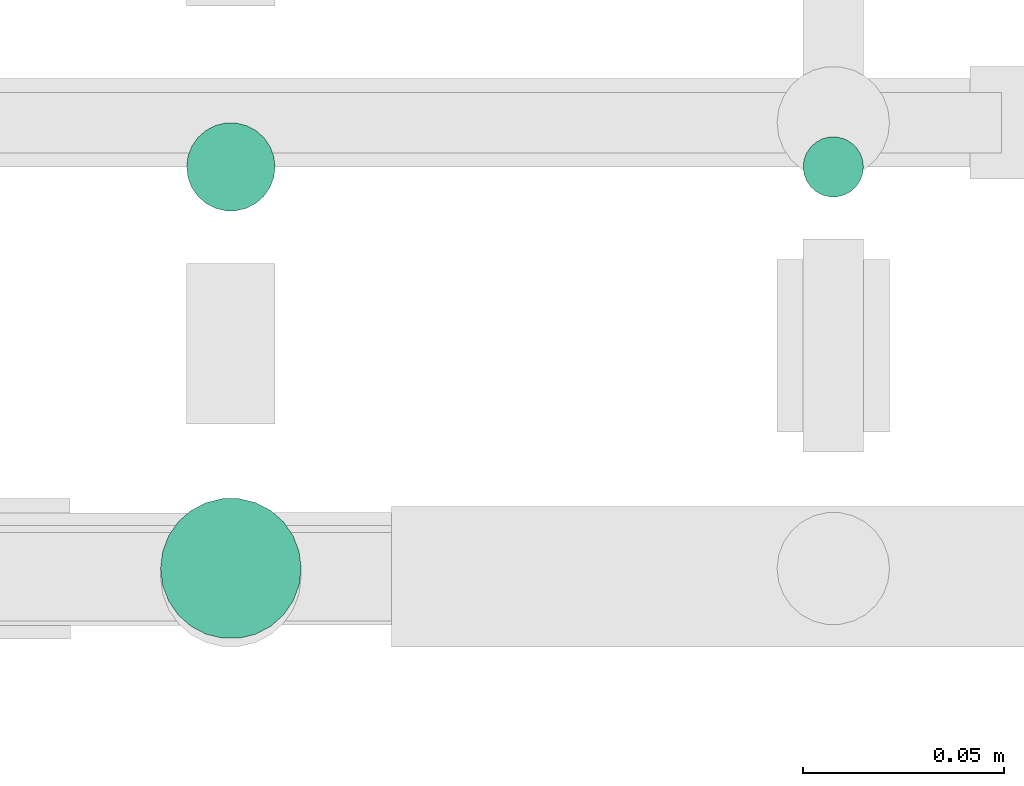
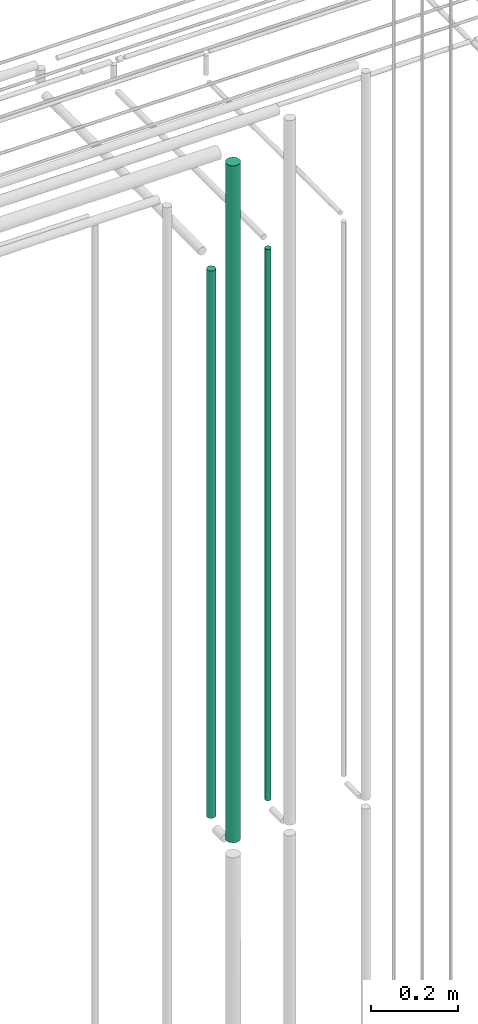
# One storey, part 93 of 331: 3 flow segments.
"""IFC2X3 building model written with IfcOpenShell, lengths in millimetres."""

import ifcopenshell
import ifcopenshell.guid

model = None  # the IFC model being written
_history = None  # IfcOwnerHistory: only IFC2X3 demands one
_inside = {}  # id of a spatial element -> (the spatial element, [elements in it])
_under = {}  # id of a project, library or spatial element -> (it, [spatial elements below it])
_declared = {}  # id of a project -> (the project, [libraries it declares])
_typed = {}  # id of a type object -> (the type object, [elements of that type])
_made_of = {}  # id of a material, layer set ... -> (it, [elements and type objects made of it])


def new_model(schema):
    """Start an empty IFC model of exactly this schema.

    Asked for "IFC4X3", IfcOpenShell would pick the latest addendum, in which some entities
    have other attributes; the version numbers below select the first issue.
    IFC2X3 requires an IfcOwnerHistory on every rooted entity: one is made here for all.
    """
    global model, _history
    if schema == "IFC4X3":
        model = ifcopenshell.file(schema_version=(4, 3, 0, 0))
    else:
        model = ifcopenshell.file(schema=schema)
    _inside.clear()
    _under.clear()
    _declared.clear()
    _typed.clear()
    _made_of.clear()
    _history = None
    if model.schema == "IFC2X3":
        org = make("IfcOrganization", Name="unknown")
        user = make(
            "IfcPersonAndOrganization",
            ThePerson=make("IfcPerson", FamilyName="unknown"),
            TheOrganization=org,
        )
        app = make(
            "IfcApplication",
            ApplicationDeveloper=org,
            Version="unknown",
            ApplicationFullName="unknown",
            ApplicationIdentifier="unknown",
        )
        _history = make(
            "IfcOwnerHistory",
            OwningUser=user,
            OwningApplication=app,
            ChangeAction="ADDED",
            CreationDate=0,
        )
    return model


def make(cls, **values):
    """One entity of the class cls with the attributes given. An attribute that is None is left unset."""
    return model.create_entity(
        cls, **{name: value for name, value in values.items() if value is not None}
    )


def entity(cls, *values):
    """Any entity or typed value of the class cls, its attributes in the order of the schema. None: left unset."""
    e = model.create_entity(cls)
    for i, value in enumerate(values):
        if value is not None:
            e[i] = value
    return e


def rooted(cls, **values):
    """An entity with a GlobalId (a new one), such as an element, a storey or a relation."""
    return make(cls, GlobalId=ifcopenshell.guid.new(), OwnerHistory=_history, **values)


def si_unit(unit_type, name, prefix=None):
    """IfcSIUnit, for example si_unit("LENGTHUNIT", "METRE", prefix="MILLI")."""
    return make("IfcSIUnit", UnitType=unit_type, Prefix=prefix, Name=name)


def converted_unit(unit_type, name, factor, base, dimensions=None, offset=None):
    """IfcConversionBasedUnit, such as the inch: factor (a typed value) times the base unit."""
    return make(
        "IfcConversionBasedUnit"
        if offset is None
        else "IfcConversionBasedUnitWithOffset",
        ConversionOffset=offset,
        Dimensions=None
        if dimensions is None
        else entity("IfcDimensionalExponents", *dimensions),
        UnitType=unit_type,
        Name=name,
        ConversionFactor=make(
            "IfcMeasureWithUnit", ValueComponent=factor, UnitComponent=base
        ),
    )


def derived_unit(unit_type, elements):
    """IfcDerivedUnit: a product of units, each with its exponent."""
    return make(
        "IfcDerivedUnit",
        Elements=[
            make("IfcDerivedUnitElement", Unit=unit, Exponent=power)
            for unit, power in elements
        ],
        UnitType=unit_type,
    )


def assignment(units):
    """IfcUnitAssignment: the units of a project."""
    return None if units is None else make("IfcUnitAssignment", Units=units)


def point(xyz):
    """IfcCartesianPoint."""
    return None if xyz is None else make("IfcCartesianPoint", Coordinates=xyz)


def direction(xyz):
    """IfcDirection."""
    return None if xyz is None else make("IfcDirection", DirectionRatios=xyz)


def frame(location, z_axis=None, x_axis=None):
    """IfcAxis2Placement3D, a coordinate frame: its origin and axes. An axis left out is left unset."""
    return make(
        "IfcAxis2Placement3D",
        Location=point(location),
        Axis=direction(z_axis),
        RefDirection=direction(x_axis),
    )


def frame_2d(location, x_axis=None):
    """IfcAxis2Placement2D, a coordinate frame in the plane: its origin and x axis."""
    return make(
        "IfcAxis2Placement2D", Location=point(location), RefDirection=direction(x_axis)
    )


def origin():
    """The frame at (0, 0, 0) with its axes left unset."""
    return frame((0.0, 0.0, 0.0))


def origin_2d_with_axis():
    """The frame at (0, 0) in the plane with the x axis (1, 0) written out."""
    return frame_2d((0.0, 0.0), x_axis=(1.0, 0.0))


def place(relative_to, where):
    """IfcLocalPlacement: puts the frame where relative to a parent placement (None: the world)."""
    return make(
        "IfcLocalPlacement", PlacementRelTo=relative_to, RelativePlacement=where
    )


def context(
    kind, dimensions, precision=None, world=None, true_north=None, identifier=None
):
    """IfcGeometricRepresentationContext, for example the 3D "Model" context."""
    return make(
        "IfcGeometricRepresentationContext",
        ContextIdentifier=identifier,
        ContextType=kind,
        CoordinateSpaceDimension=dimensions,
        Precision=precision,
        WorldCoordinateSystem=world,
        TrueNorth=true_north,
    )


def subcontext(parent, identifier, kind, view, scale=None):
    """IfcGeometricRepresentationSubContext, for example "Body" below "Model"."""
    return make(
        "IfcGeometricRepresentationSubContext",
        ContextIdentifier=identifier,
        ContextType=kind,
        ParentContext=parent,
        TargetScale=scale,
        TargetView=view,
    )


def project(units=None, contexts=None):
    """IfcProject with its units and contexts."""
    return rooted(
        "IfcProject",
        Name="project",
        RepresentationContexts=contexts,
        UnitsInContext=assignment(units),
    )


def spatial(cls, under=None, at=None, **own):
    """A site, building, storey or space (cls), placed at a placement, below another one or the project."""
    s = rooted(cls, ObjectPlacement=at, **own)
    if under is not None:
        _under.setdefault(under.id(), (under, []))[1].append(s)
    return s


def profile(cls, at=None, kind="AREA", **sizes):
    """A parametric profile (cls). Its sizes go by their IFC names, for example OverallWidth=200.0."""
    return make(cls, ProfileType=kind, Position=at, **sizes)


def circle(**sizes):
    """IfcCircleProfileDef."""
    return profile("IfcCircleProfileDef", **sizes)


def extrude(swept, where, along, depth):
    """IfcExtrudedAreaSolid: the profile swept, set in the frame where, extruded along a direction by depth."""
    return make(
        "IfcExtrudedAreaSolid",
        SweptArea=swept,
        Position=where,
        ExtrudedDirection=direction(along),
        Depth=depth,
    )


def shape(context_of_items, identifier, shape_type, items):
    """IfcShapeRepresentation: the items that make up one representation, for example the "Body"."""
    return make(
        "IfcShapeRepresentation",
        ContextOfItems=context_of_items,
        RepresentationIdentifier=identifier,
        RepresentationType=shape_type,
        Items=items,
    )


def made_of(thing, what):
    """Note that an element or type object is made of a material, layer set ...; save() writes the relation."""
    if what is not None:
        _made_of.setdefault(what.id(), (what, []))[1].append(thing)
    return thing


def type_object(cls, material=None, **own):
    """A type object (cls), such as IfcWallType, which elements share."""
    return made_of(rooted(cls, **own), material)


def element(
    cls,
    number,
    at=None,
    inside=None,
    cuts=None,
    type_object=None,
    material=None,
    context=None,
    identifier="Body",
    shape_type=None,
    held_by="IfcProductDefinitionShape",
    body=None,
    shapes=None,
    **own,
):
    """One element of the class cls, such as IfcWall. Its Tag is "e" and its number.

    at: its placement. inside: the storey or other place that contains it. cuts: it is an
    opening in that element (IfcRelVoidsElement). A single representation is given by context,
    identifier, shape_type and body (its items); several are given by shapes. held_by: the class
    of the entity that holds the representations. save() writes the other relations.
    """
    e = rooted(cls, Tag="e%d" % number, ObjectPlacement=at, **own)
    if body is not None:
        shapes = [shape(context, identifier, shape_type, body)]
    if shapes is not None:
        e.Representation = make(held_by, Representations=shapes)
    if inside is not None:
        _inside.setdefault(inside.id(), (inside, []))[1].append(e)
    if cuts is not None:
        rooted(
            "IfcRelVoidsElement", RelatingBuildingElement=cuts, RelatedOpeningElement=e
        )
    if type_object is not None:
        _typed.setdefault(type_object.id(), (type_object, []))[1].append(e)
    return made_of(e, material)


def aggregate(whole, parts):
    """IfcRelAggregates: a whole, such as a stair, and the parts it consists of."""
    return rooted("IfcRelAggregates", RelatingObject=whole, RelatedObjects=parts)


def save(model, path):
    """Write the relations noted so far, then the file.

    IfcRelAggregates (storeys below a building ...), IfcRelContainedInSpatialStructure (elements
    in a storey), IfcRelDefinesByType, IfcRelAssociatesMaterial and IfcRelDeclares: one each for
    every whole, place, type object, material and project.
    """
    for whole, parts in _under.values():
        aggregate(whole, parts)
    for where, things in _inside.values():
        rooted(
            "IfcRelContainedInSpatialStructure",
            RelatedElements=things,
            RelatingStructure=where,
        )
    for kind, things in _typed.values():
        rooted("IfcRelDefinesByType", RelatedObjects=things, RelatingType=kind)
    for what, things in _made_of.values():
        rooted("IfcRelAssociatesMaterial", RelatedObjects=things, RelatingMaterial=what)
    for by, libraries in _declared.values():
        rooted("IfcRelDeclares", RelatingContext=by, RelatedDefinitions=libraries)
    model.write(path)


model = new_model("IFC2X3")

# Units and contexts
model_context = context("Model", 3, precision=0.01, world=origin(), true_north=direction((6.12303176911189e-17, 1.0)))
body_context = subcontext(model_context, "Body", "Model", "MODEL_VIEW")
ifc_project = project(units=[si_unit("LENGTHUNIT", "METRE", prefix="MILLI"), si_unit("AREAUNIT", "SQUARE_METRE"), si_unit("VOLUMEUNIT", "CUBIC_METRE"), converted_unit("PLANEANGLEUNIT", "DEGREE", entity("IfcRatioMeasure", 0.0174532925199433), si_unit("PLANEANGLEUNIT", "RADIAN"), dimensions=[0, 0, 0, 0, 0, 0, 0]), si_unit("MASSUNIT", "GRAM", prefix="KILO"), derived_unit("MASSDENSITYUNIT", [(si_unit("MASSUNIT", "GRAM", prefix="KILO"), 1), (si_unit("LENGTHUNIT", "METRE"), -3)]), derived_unit("MOMENTOFINERTIAUNIT", [(si_unit("LENGTHUNIT", "METRE"), 4)]), si_unit("TIMEUNIT", "SECOND"), si_unit("FREQUENCYUNIT", "HERTZ"), si_unit("THERMODYNAMICTEMPERATUREUNIT", "DEGREE_CELSIUS"), derived_unit("THERMALTRANSMITTANCEUNIT", [(si_unit("MASSUNIT", "GRAM", prefix="KILO"), 1), (si_unit("THERMODYNAMICTEMPERATUREUNIT", "KELVIN"), -1), (si_unit("TIMEUNIT", "SECOND"), -3)]), derived_unit("VOLUMETRICFLOWRATEUNIT", [(si_unit("LENGTHUNIT", "METRE"), 3), (si_unit("TIMEUNIT", "SECOND"), -1)]), derived_unit("MASSFLOWRATEUNIT", [(si_unit("MASSUNIT", "GRAM", prefix="KILO"), 1), (si_unit("TIMEUNIT", "SECOND"), -1)]), derived_unit("ROTATIONALFREQUENCYUNIT", [(si_unit("TIMEUNIT", "SECOND"), -1)]), si_unit("ELECTRICCURRENTUNIT", "AMPERE"), si_unit("ELECTRICVOLTAGEUNIT", "VOLT"), si_unit("POWERUNIT", "WATT"), si_unit("FORCEUNIT", "NEWTON", prefix="KILO"), si_unit("ILLUMINANCEUNIT", "LUX"), si_unit("LUMINOUSFLUXUNIT", "LUMEN"), si_unit("LUMINOUSINTENSITYUNIT", "CANDELA"), derived_unit("USERDEFINED", [(si_unit("MASSUNIT", "GRAM", prefix="KILO"), -1), (si_unit("LENGTHUNIT", "METRE"), -2), (si_unit("TIMEUNIT", "SECOND"), 3), (si_unit("LUMINOUSFLUXUNIT", "LUMEN"), 1)]), derived_unit("LINEARVELOCITYUNIT", [(si_unit("LENGTHUNIT", "METRE"), 1), (si_unit("TIMEUNIT", "SECOND"), -1)]), si_unit("PRESSUREUNIT", "PASCAL"), derived_unit("USERDEFINED", [(si_unit("LENGTHUNIT", "METRE"), -2), (si_unit("MASSUNIT", "GRAM", prefix="KILO"), 1), (si_unit("TIMEUNIT", "SECOND"), -2)]), derived_unit("LINEARFORCEUNIT", [(si_unit("MASSUNIT", "GRAM", prefix="KILO"), 1), (si_unit("LENGTHUNIT", "METRE"), 1), (si_unit("TIMEUNIT", "SECOND"), -2), (si_unit("LENGTHUNIT", "METRE"), -1)]), derived_unit("PLANARFORCEUNIT", [(si_unit("MASSUNIT", "GRAM", prefix="KILO"), 1), (si_unit("LENGTHUNIT", "METRE"), 1), (si_unit("TIMEUNIT", "SECOND"), -2), (si_unit("LENGTHUNIT", "METRE"), -2)])], contexts=[model_context])

# Site, building, storey
site_placement = place(None, frame((0.0, -0.00077364408347762, 0.0)))
site = spatial("IfcSite", under=ifc_project, at=site_placement, CompositionType="ELEMENT")
building_placement = place(site_placement, origin())
building = spatial("IfcBuilding", under=site, at=building_placement, CompositionType="ELEMENT")
storey_placement = place(building_placement, origin())
storey = spatial("IfcBuildingStorey", under=building, at=storey_placement, CompositionType="ELEMENT", Elevation=0.0)

# Flow segments
pipe_segment_type = type_object("IfcPipeSegmentType", PredefinedType="NOTDEFINED")
flow_segment_1_placement = place(building_placement, frame((66501.0166110417, 8240.90537015909, 5118.0)))
element("IfcFlowSegment", 1, at=flow_segment_1_placement, inside=storey, type_object=pipe_segment_type, context=body_context, shape_type="SweptSolid", body=[
    extrude(circle(Radius=7.5, at=frame_2d((-8.66293703438714e-12, 0.0), x_axis=(1.0, 0.0))), frame((9.09527223590553, 9.09527223591636, 0.0), z_axis=(0.0, 0.0, 1.0), x_axis=(-1.0, 0.0, 0.0)), (0.0, 0.0, 1.0), 1538.99999999997),
])
flow_segment_2_placement = place(building_placement, frame((66347.5166110417, 8237.40537015836, 5124.00018972501)))
element("IfcFlowSegment", 2, at=flow_segment_2_placement, inside=storey, type_object=pipe_segment_type, context=body_context, shape_type="SweptSolid", body=[
    extrude(circle(Radius=11.0, at=origin_2d_with_axis()), frame((12.5952722359134, 12.5952722359156, 0.0), z_axis=(0.0, 0.0, 1.0), x_axis=(-1.0, 0.0, 0.0)), (0.0, 0.0, 1.0), 1526.99981027499),
])
flow_segment_3_placement = place(building_placement, frame((66341.0166110417, 8130.92627299877, 5121.0)))
element("IfcFlowSegment", 3, at=flow_segment_3_placement, inside=storey, type_object=pipe_segment_type, context=body_context, shape_type="SweptSolid", body=[
    extrude(circle(Radius=17.5, at=frame_2d((-8.66293703438714e-12, 0.0), x_axis=(1.0, 0.0))), frame((19.0952722359033, 19.0952722359163, 0.0), z_axis=(0.0, 0.0, 1.0), x_axis=(-1.0, 0.0, 0.0)), (0.0, 0.0, 1.0), 1889.00000000084),
])

save(model, "model.ifc")
